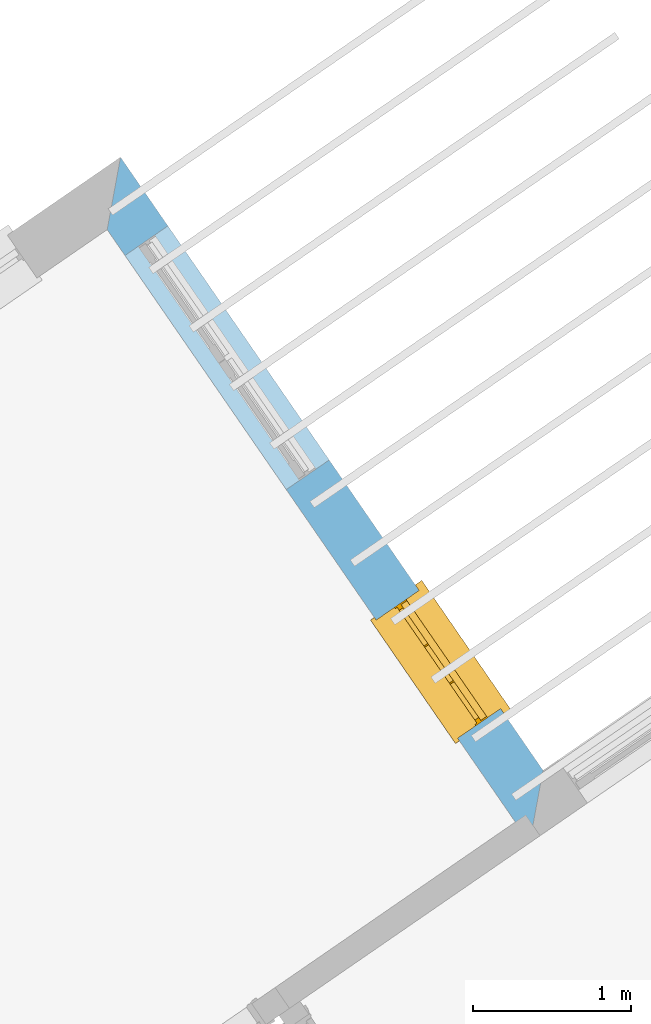
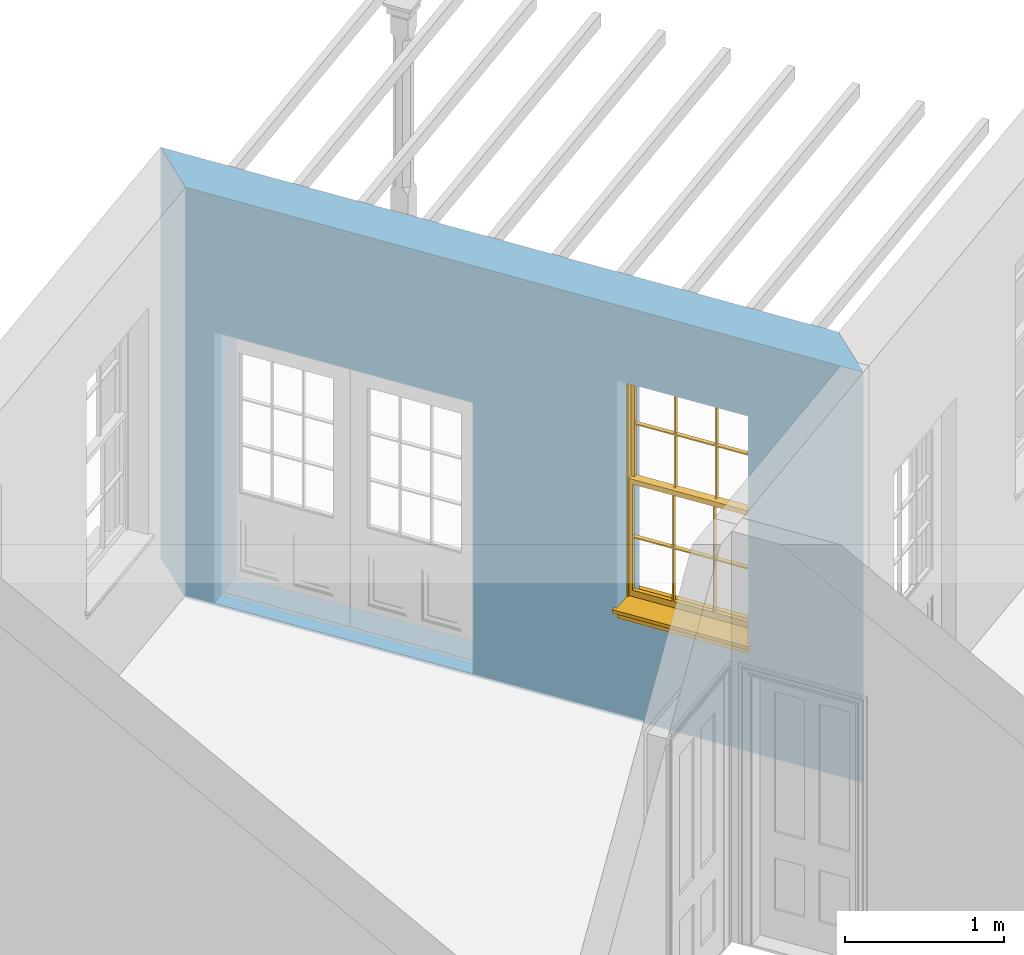
# One storey, part 7 of 12: 1 window, 2 openings, plus 1 element that does not belong to this part.
"""IFC2X3 building model written with IfcOpenShell, lengths in metres."""

from ifc_helpers import new_model, si_unit, frame, origin, place, context, subcontext, project, spatial, polyline, outline, extrude, faceted_brep, material, layer, layer_set, layer_usage, element, fill, save


model = new_model("IFC2X3")

# Units and contexts
model_context = context("Model", 3, world=origin())
body_context = subcontext(model_context, "Body", "Model", "MODEL_VIEW")
ifc_project = project(units=[si_unit("PLANEANGLEUNIT", "RADIAN"), si_unit("MASSUNIT", "GRAM", prefix="KILO"), si_unit("FORCEUNIT", "NEWTON", prefix="KILO"), si_unit("LENGTHUNIT", "METRE")], contexts=[model_context])

# Site, building, storey
site_placement = place(None, origin())
site = spatial("IfcSite", under=ifc_project, at=site_placement, CompositionType="ELEMENT")
building_placement = place(None, origin())
building = spatial("IfcBuilding", under=site, at=building_placement, Name="Building plot-7", CompositionType="ELEMENT")
storey_placement = place(None, frame((0.0, 0.0, 8.0)))
storey = spatial("IfcBuildingStorey", under=building, at=storey_placement, Name="Floor 1", CompositionType="ELEMENT", Elevation=8.0)

# Wall, openings, window
ifc_material = material(Name="Masonry")
ifc_layer = layer(ifc_material, 0.33, ventilated=False)
ifc_layer_set = layer_set([ifc_layer], Name="My Wall")
ifc_layer_usage = layer_usage(ifc_layer_set, "AXIS2", "NEGATIVE", 0.08)
wall_placement = place(storey_placement, origin())
wall = element("IfcWallStandardCase", 1, at=wall_placement, inside=storey, material=ifc_layer_usage, Name="exterior", context=body_context, shape_type="SweptSolid", body=[
    extrude(outline(polyline([(88.1099803913297, 67.5367543573869), (88.1944908209502, 67.9957292883857), (85.5190596071891, 71.8787614387522), (85.4345491775686, 71.4197865077534), (88.1099803913297, 67.5367543573869)])), origin(), (0.0, 0.0, 1.0), 3.15),
])
opening_1_placement = place(storey_placement, frame((0.0, 0.0, 0.75)))
opening_1 = element("IfcOpeningElement", 2, at=opening_1_placement, cuts=wall, Name="Opening", ObjectType="Opening", context=body_context, shape_type="SweptSolid", body=[
    extrude(outline(polyline([(87.9256291894368, 68.3859461453158), (87.4093220739, 69.1352971728363), (87.1375793935903, 68.9480649221472), (87.6538865091271, 68.1987138946266), (87.9256291894368, 68.3859461453158)])), origin(), (0.0, 0.0, 1.0), 1.82),
])
opening_2_placement = place(storey_placement, frame((0.0, 0.0, 0.0199999999999996)))
element("IfcOpeningElement", 3, at=opening_2_placement, cuts=wall, Name="Opening", ObjectType="Opening", context=body_context, shape_type="SweptSolid", body=[
    extrude(outline(polyline([(86.8403934357583, 69.9610213334149), (85.8191266138174, 71.4432541351038), (85.5473839335077, 71.2560218844146), (86.5686507554486, 69.7737890827257), (86.8403934357583, 69.9610213334149)])), origin(), (0.0, 0.0, 1.0), 2.08),
])
window_placement = place(storey_placement, frame((87.7197635225355, 68.2441035311574, 0.75), z_axis=(0.0, 0.0, 1.0), x_axis=(-0.51630711553679, 0.749351027520532, 0.0)))
window = element("IfcWindow", 4, at=window_placement, inside=storey, Name="living outside window", OverallHeight=1.82, OverallWidth=0.91, context=body_context, shape_type="Brep", held_by="IfcProductRepresentation", body=[
    faceted_brep([(0.033125, -0.105, 0.975209), (0.01, -0.105, 0.975209), (0.033125, -0.105, 1.376042), (0.876875, -0.105, 0.975209), (0.876875, -0.105, 1.376042), (0.9, -0.105, 0.975209), (0.876875, -0.105, 1.386042), (0.876875, -0.105, 1.786875), (0.9, -0.105, 1.81), (0.033125, -0.105, 1.786875), (0.033125, -0.105, 1.386042), (0.01, -0.105, 1.81), (0.876875, -0.135, 1.376042), (0.876875, -0.135, 0.975209), (0.9, -0.135, 0.937083), (0.033125, -0.135, 1.786875), (0.01, -0.135, 1.81), (0.033125, -0.135, 1.386042), (0.01, -0.135, 0.937083), (0.033125, -0.135, 0.975209), (0.033125, -0.135, 1.376042), (0.876875, -0.135, 1.786875), (0.876875, -0.135, 1.386042), (0.9, -0.135, 1.81), (0.033125, -0.105, 0.937083), (0.01, -0.105, 0.937083), (0.033125, -0.105, 0.53625), (0.876875, -0.105, 0.937083), (0.876875, -0.105, 0.53625), (0.9, -0.105, 0.937083), (0.876875, -0.105, 0.52625), (0.876875, -0.105, 0.125417), (0.9, -0.105, 0.077167), (0.033125, -0.105, 0.125417), (0.033125, -0.105, 0.52625), (0.01, -0.105, 0.077167), (-0.0425, -0.25, 0.01), (-0.0425, -0.3, 0.001667), (0.0, -0.25, 0.01), (0.9525, -0.25, 0.01), (0.91, -0.25, 0.01), (0.9525, -0.3, 0.001667), (-0.02, 0.08, 0.077167), (0.0, 0.08, 0.077167), (-0.02, 0.11, 0.077167), (0.0, -0.06, 0.077167), (0.01, -0.06, 0.077167), (0.91, -0.06, 0.077167), (0.91, 0.08, 0.077167), (0.9, -0.06, 0.077167), (0.93, 0.08, 0.077167), (0.93, 0.11, 0.077167), (0.01, -0.075, 0.975209), (0.9, -0.075, 0.975209), (0.876875, -0.075, 0.125417), (0.876875, -0.075, 0.52625), (0.9, -0.075, 0.077167), (0.876875, -0.075, 0.53625), (0.876875, -0.075, 0.937083), (0.033125, -0.075, 0.125417), (0.01, -0.075, 0.077167), (0.033125, -0.075, 0.52625), (0.033125, -0.075, 0.937083), (0.033125, -0.075, 0.53625), (-0.02, 0.08, 0.052167), (-0.02, 0.11, 0.052167), (0.93, 0.11, 0.052167), (0.93, 0.08, 0.052167), (0.91, 0.08, 0.052167), (0.0, 0.08, 0.052167), (0.91, -0.15, 0.026667), (0.0, -0.15, 0.026667), (-0.0425, -0.3, -0.123333), (0.9525, -0.3, -0.123333), (-0.0425, -0.25, -0.123333), (0.9525, -0.25, -0.123333), (0.01, -0.06, 1.81), (0.9, -0.06, 1.81), (0.0, -0.06, 1.82), (0.91, -0.06, 1.82), (0.01, -0.15, 0.077167), (0.9, -0.15, 0.077167), (0.592292, -0.105, 0.125417), (0.592292, -0.075, 0.125417), (0.317708, -0.075, 0.125417), (0.317708, -0.105, 0.125417), (0.592292, -0.105, 0.53625), (0.317708, -0.105, 0.53625), (0.317708, -0.105, 0.52625), (0.592292, -0.105, 0.52625), (0.592292, -0.075, 0.53625), (0.317708, -0.075, 0.53625), (0.592292, -0.135, 1.386042), (0.592292, -0.105, 1.386042), (0.317708, -0.105, 1.386042), (0.317708, -0.135, 1.386042), (0.317708, -0.135, 1.376042), (0.592292, -0.135, 1.376042), (0.317708, -0.105, 1.376042), (0.592292, -0.105, 1.376042), (0.602292, -0.135, 1.376042), (0.592292, -0.135, 0.975209), (0.602292, -0.135, 0.975209), (0.602292, -0.105, 0.975209), (0.592292, -0.105, 0.975209), (0.602292, -0.105, 1.376042), (0.602292, -0.075, 0.53625), (0.602292, -0.105, 0.53625), (0.317708, -0.075, 0.52625), (0.307708, -0.075, 0.125417), (0.307708, -0.075, 0.52625), (0.602292, -0.075, 0.52625), (0.602292, -0.075, 0.125417), (0.592292, -0.075, 0.52625), (0.307708, -0.075, 0.53625), (0.317708, -0.075, 0.937083), (0.307708, -0.075, 0.937083), (0.602292, -0.075, 0.937083), (0.592292, -0.075, 0.937083), (0.307708, -0.105, 0.52625), (0.307708, -0.105, 0.125417), (0.307708, -0.105, 0.53625), (0.307708, -0.105, 0.937083), (0.592292, -0.105, 0.937083), (0.317708, -0.105, 0.937083), (0.602292, -0.105, 0.937083), (0.602292, -0.105, 0.52625), (0.602292, -0.105, 0.125417), (0.307708, -0.135, 1.386042), (0.307708, -0.135, 1.376042), (0.307708, -0.135, 0.975209), (0.317708, -0.135, 0.975209), (0.317708, -0.135, 1.786875), (0.307708, -0.135, 1.786875), (0.602292, -0.135, 1.786875), (0.592292, -0.135, 1.786875), (0.602292, -0.135, 1.386042), (0.602292, -0.105, 1.386042), (0.307708, -0.105, 1.386042), (0.307708, -0.105, 1.786875), (0.317708, -0.105, 1.786875), (0.592292, -0.105, 1.786875), (0.602292, -0.105, 1.786875), (0.307708, -0.105, 1.376042), (0.317708, -0.105, 0.975209), (0.307708, -0.105, 0.975209), (0.91, -0.15, 1.82), (0.9, -0.15, 1.81), (0.01, -0.15, 1.81), (0.0, -0.15, 1.82), (0.91, -0.25, 0.0), (0.0, -0.25, 0.0), (0.91, 0.08, 0.0), (0.0, 0.08, 0.0)], [[[0, 1, 2]], [[3, 4, 5]], [[6, 7, 8]], [[9, 10, 11]], [[12, 13, 14]], [[15, 16, 17]], [[18, 19, 20]], [[21, 22, 23]], [[24, 25, 26]], [[27, 28, 29]], [[30, 31, 32]], [[33, 34, 35]], [[14, 27, 29]], [[25, 24, 18]], [[36, 37, 38]], [[39, 40, 41]], [[42, 43, 44]], [[45, 46, 43]], [[47, 48, 49]], [[50, 51, 48]], [[1, 0, 52]], [[5, 53, 3]], [[54, 55, 56]], [[57, 58, 53]], [[59, 60, 61]], [[62, 63, 52]], [[48, 43, 46, 49]], [[51, 44, 43, 48]], [[64, 42, 44, 65]], [[65, 44, 51, 66]], [[66, 51, 50, 67]], [[65, 66, 68, 69]], [[60, 56, 49, 46]], [[70, 71, 38, 40]], [[37, 41, 40, 38]], [[37, 72, 73, 41]], [[74, 75, 73, 72]], [[8, 11, 76, 77]], [[76, 78, 79, 77]], [[32, 35, 80, 81]], [[81, 80, 71, 70]], [[82, 83, 84, 85]], [[86, 87, 88, 89]], [[86, 90, 91, 87]], [[92, 93, 94, 95]], [[92, 95, 96, 97]], [[96, 98, 99, 97]], [[100, 97, 101, 102]], [[103, 104, 99, 105]], [[97, 99, 104, 101]], [[102, 103, 105, 100]], [[28, 57, 106, 107]], [[108, 84, 109, 110]], [[111, 112, 83, 113]], [[114, 110, 61, 63]], [[90, 113, 108, 91]], [[115, 91, 114, 116]], [[117, 106, 90, 118]], [[111, 106, 57, 55]], [[119, 110, 109, 120]], [[34, 61, 110, 119]], [[89, 113, 83, 82]], [[88, 108, 113, 89]], [[85, 84, 108, 88]], [[121, 114, 63, 26]], [[122, 116, 114, 121]], [[123, 118, 90, 86]], [[87, 91, 115, 124]], [[107, 106, 117, 125]], [[126, 111, 55, 30]], [[127, 112, 111, 126]], [[126, 30, 28, 107]], [[88, 119, 120, 85]], [[126, 89, 82, 127]], [[125, 123, 86, 107]], [[121, 26, 34, 119]], [[124, 122, 121, 87]], [[128, 17, 20, 129]], [[96, 129, 130, 131]], [[132, 133, 128, 95]], [[134, 135, 92, 136]], [[100, 12, 22, 136]], [[137, 6, 4, 105]], [[94, 138, 139, 140]], [[137, 93, 141, 142]], [[99, 98, 94, 93]], [[143, 2, 10, 138]], [[144, 145, 143, 98]], [[129, 143, 145, 130]], [[20, 2, 143, 129]], [[131, 144, 98, 96]], [[128, 138, 10, 17]], [[133, 139, 138, 128]], [[135, 141, 93, 92]], [[95, 94, 140, 132]], [[22, 6, 137, 136]], [[136, 137, 142, 134]], [[100, 105, 4, 12]], [[107, 86, 89, 126]], [[106, 111, 113, 90]], [[91, 108, 110, 114]], [[87, 121, 119, 88]], [[97, 100, 136, 92]], [[129, 96, 95, 128]], [[98, 143, 138, 94]], [[105, 99, 93, 137]], [[131, 101, 104, 144]], [[124, 115, 118, 123]], [[132, 140, 141, 135]], [[120, 109, 59, 33]], [[15, 9, 139, 133]], [[134, 142, 7, 21]], [[31, 54, 112, 127]], [[36, 74, 72, 37]], [[39, 41, 73, 75]], [[18, 14, 101, 131]], [[23, 16, 132, 135]], [[83, 56, 60, 84]], [[52, 53, 118, 115]], [[53, 52, 144, 104]], [[11, 8, 141, 140]], [[14, 18, 124, 123]], [[2, 1, 11, 10]], [[8, 5, 4, 6]], [[57, 53, 56, 55]], [[60, 52, 63, 61]], [[26, 25, 35, 34]], [[32, 29, 28, 30]], [[14, 23, 22, 12]], [[18, 20, 17, 16]], [[19, 0, 2, 20]], [[17, 10, 9, 15]], [[12, 4, 3, 13]], [[21, 7, 6, 22]], [[27, 58, 57, 28]], [[30, 55, 54, 31]], [[33, 59, 61, 34]], [[26, 63, 62, 24]], [[5, 8, 77, 53]], [[76, 11, 1, 52]], [[46, 45, 78, 76]], [[49, 77, 79, 47]], [[70, 146, 147, 81]], [[71, 80, 148, 149]], [[19, 130, 145, 0]], [[102, 13, 3, 103]], [[116, 122, 24, 62]], [[29, 32, 81, 14]], [[80, 35, 25, 18]], [[60, 46, 76, 52]], [[77, 49, 56, 53]], [[23, 14, 81, 147]], [[16, 148, 80, 18]], [[35, 85, 120]], [[120, 33, 35]], [[127, 82, 32]], [[32, 31, 127]], [[32, 82, 85, 35]], [[102, 101, 14]], [[14, 13, 102]], [[18, 131, 130]], [[130, 19, 18]], [[134, 21, 23]], [[23, 135, 134]], [[16, 15, 133]], [[133, 132, 16]], [[11, 140, 139]], [[139, 9, 11]], [[142, 141, 8]], [[8, 7, 142]], [[23, 147, 148, 16]], [[146, 149, 148, 147]], [[52, 115, 116]], [[116, 62, 52]], [[118, 53, 117]], [[58, 117, 53]], [[27, 125, 117, 58]], [[56, 83, 112]], [[112, 54, 56]], [[109, 84, 60]], [[60, 59, 109]], [[125, 27, 14]], [[14, 123, 125]], [[122, 124, 18]], [[18, 24, 122]], [[145, 144, 52]], [[52, 0, 145]], [[103, 3, 53]], [[53, 104, 103]], [[79, 78, 149, 146]], [[78, 45, 71, 149]], [[146, 70, 47, 79]], [[150, 75, 74, 151]], [[68, 66, 67]], [[48, 68, 67, 50]], [[69, 64, 65]], [[42, 64, 69, 43]], [[69, 68, 152, 153]], [[70, 68, 48, 47]], [[150, 152, 68, 70]], [[43, 69, 71, 45]], [[69, 153, 151, 71]], [[152, 150, 151, 153]], [[38, 151, 74, 36]], [[71, 151, 38]], [[39, 75, 150, 40]], [[40, 150, 70]]]),
])
fill(opening_1, window)

save(model, "model.ifc")
